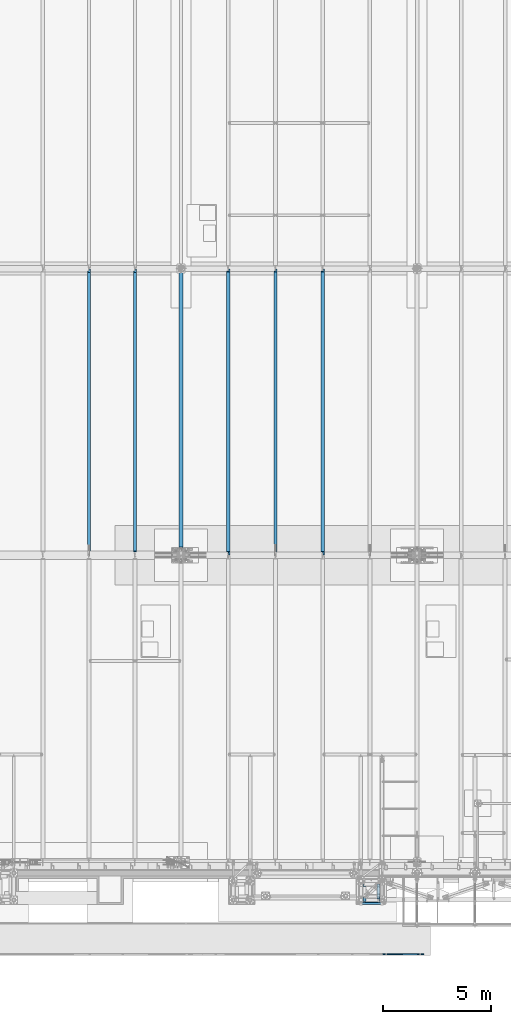
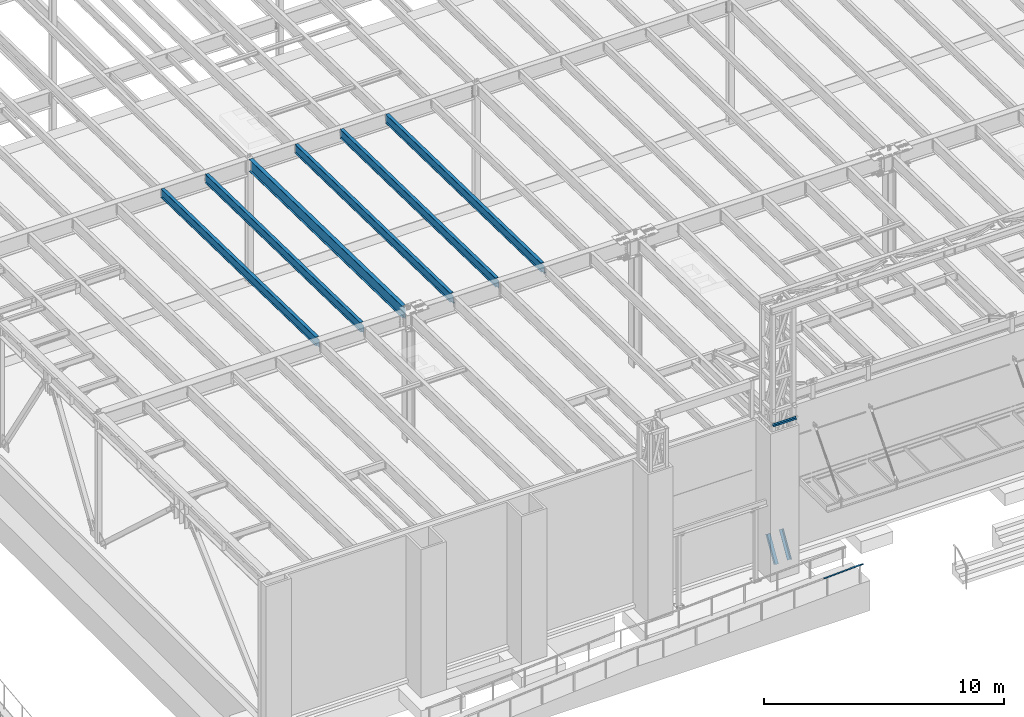
# One storey, part 1051 of 1763: 8 beams, 2 members, 8 elements without a shape of their own.
"""IFC2X3 building model written with IfcOpenShell, lengths in millimetres."""

from ifc_helpers import new_model, si_unit, frame, origin_with_axes, place, context, subcontext, project, spatial, faceted_brep, material, type_object, element, aggregate, save


model = new_model("IFC2X3")

# Units and contexts
model_context = context("Model", 3, precision=1e-05, world=origin_with_axes())
body_context = subcontext(model_context, "Body", "Model", "MODEL_VIEW")
ifc_project = project(units=[si_unit("LENGTHUNIT", "METRE", prefix="MILLI"), si_unit("AREAUNIT", "SQUARE_METRE"), si_unit("VOLUMEUNIT", "CUBIC_METRE"), si_unit("MASSUNIT", "GRAM", prefix="KILO"), si_unit("TIMEUNIT", "SECOND"), si_unit("PLANEANGLEUNIT", "RADIAN"), si_unit("SOLIDANGLEUNIT", "STERADIAN"), si_unit("THERMODYNAMICTEMPERATUREUNIT", "DEGREE_CELSIUS"), si_unit("LUMINOUSINTENSITYUNIT", "LUMEN")], contexts=[model_context])

# Site, building, storey
site_placement = place(None, origin_with_axes())
site = spatial("IfcSite", under=ifc_project, at=site_placement, CompositionType="ELEMENT")
building_placement = place(site_placement, origin_with_axes())
building = spatial("IfcBuilding", under=site, at=building_placement, Name="Undefined", CompositionType="ELEMENT")
storey_placement = place(building_placement, origin_with_axes())
storey = spatial("IfcBuildingStorey", under=building, at=storey_placement, Name="Undefined", CompositionType="ELEMENT", Elevation=0.0)

# Assembly, members, beam
assembly_1_placement = place(storey_placement, origin_with_axes())
assembly_1 = element("IfcElementAssembly", 1, at=assembly_1_placement, inside=storey, Name="FRAME", AssemblyPlace="NOTDEFINED", PredefinedType="RIGID_FRAME")
ifc_material_1 = material(Name="STEEL/A36")
member_type = type_object("IfcMemberType", Name="L6X6X7/8", PredefinedType="NOTDEFINED")
member_1_placement = place(assembly_1_placement, frame((-63375.6025956311, -15452.7273134574, 5676.9), z_axis=(-1.0, 0.0, 0.0), x_axis=(0.0, 0.513027731048337, 0.858372033080875)))
member_1 = element("IfcMember", 2, at=member_1_placement, type_object=member_type, material=ifc_material_1, Name="V. BRACE", ObjectType="L6X6X7/8", context=body_context, shape_type="Brep", body=[
    faceted_brep([(9.09494701772928e-13, 76.2000000000007, -76.2000000000844), (0.0, 76.2000000000007, 76.2000000000771), (1326.04215441225, 76.2000000009157, 76.1999999999971), (1326.04215441225, 76.2000000009157, -76.1999999999971), (0.0, 53.9750000000004, 76.2000000000771), (1326.04215441225, 53.9750000009208, 76.1999999999971), (1.81898940354586e-12, 53.9750000000004, -53.9750000000604), (1326.04215441225, 53.9750000009208, -53.9749999999985), (1.81898940354586e-12, -76.2000000000007, -53.9750000000604), (1326.04215441224, -76.199999999053, -53.9749999999985), (9.09494701772928e-13, -76.2000000000007, -76.2000000000844), (1326.04215441224, -76.199999999053, -76.1999999999971)], [[[0, 1, 2, 3]], [[1, 4, 5, 2]], [[4, 6, 7, 5]], [[6, 8, 9, 7]], [[8, 10, 11, 9]], [[10, 0, 3, 11]], [[5, 7, 9, 11, 3, 2]], [[10, 8, 6, 4, 1, 0]]]),
])
member_2_placement = place(assembly_1_placement, frame((-64020.1273899732, -15452.7273151589, 5676.9), z_axis=(1.0, 0.0, 0.0), x_axis=(0.0, 0.513027731048337, 0.858372033080875)))
member_2 = element("IfcMember", 3, at=member_2_placement, type_object=member_type, material=ifc_material_1, Name="V. BRACE", ObjectType="L6X6X7/8", context=body_context, shape_type="Brep", body=[
    faceted_brep([(9.09494701772928e-13, 76.2000000000007, -76.2000000000844), (0.0, 76.2000000000007, 76.2000000000771), (1326.04215441225, 76.2000000009157, 76.1999999999971), (1326.04215441225, 76.2000000009157, -76.1999999999971), (0.0, 53.9750000000004, 76.2000000000771), (1326.04215441225, 53.9750000009208, 76.1999999999971), (1.81898940354586e-12, 53.9750000000004, -53.9750000000604), (1326.04215441225, 53.9750000009208, -53.9749999999985), (1.81898940354586e-12, -76.2000000000007, -53.9750000000604), (1326.04215441224, -76.199999999053, -53.9749999999985), (9.09494701772928e-13, -76.2000000000007, -76.2000000000844), (1326.04215441224, -76.199999999053, -76.1999999999971)], [[[0, 1, 2, 3]], [[1, 4, 5, 2]], [[4, 6, 7, 5]], [[6, 8, 9, 7]], [[8, 10, 11, 9]], [[10, 0, 3, 11]], [[5, 7, 9, 11, 3, 2]], [[10, 8, 6, 4, 1, 0]]]),
])
beam_type_1 = type_object("IfcBeamType", Name="L4X4X3/8", PredefinedType="NOTDEFINED")
beam_1_placement = place(assembly_1_placement, frame((-63134.3025957006, -15608.3024208798, 12903.2), z_axis=(0.0, -1.0, 0.0), x_axis=(-1.0, 0.0, 0.0)))
beam_1 = element("IfcBeam", 4, at=beam_1_placement, type_object=beam_type_1, material=ifc_material_1, Name="ANGLE", ObjectType="L4X4X3/8", context=body_context, shape_type="Brep", body=[
    faceted_brep([(-3.63797880709171e-11, 50.8000000000011, -50.8000000000538), (-1.96450855582952e-10, 50.8000000000393, 50.7999999999374), (1127.1251953125, 50.7999999999993, 50.7999999999993), (1127.1251953125, 50.7999999999993, -50.7999999999993), (0.0, 41.2749999999996, 50.7999999999993), (1127.1251953125, 41.2749999999996, 50.7999999999993), (0.0, 41.2749999999996, -41.2750000000015), (1127.1251953125, 41.2749999999996, -41.2749999999996), (0.0, -50.7999999999993, -41.2750000000015), (1127.1251953125, -50.7999999999993, -41.2749999999996), (2.11002770811319e-10, -50.8000000000357, -50.799999999952), (1127.1251953125, -50.7999999999993, -50.7999999999993)], [[[0, 1, 2, 3]], [[1, 4, 5, 2]], [[4, 6, 7, 5]], [[6, 8, 9, 7]], [[8, 10, 11, 9]], [[10, 0, 3, 11]], [[5, 7, 9, 11, 3, 2]], [[10, 8, 6, 4, 1, 0]]]),
])
aggregate(assembly_1, [beam_1, member_1, member_2])

# Assembly, beam
assembly_2_placement = place(storey_placement, origin_with_axes())
assembly_2 = element("IfcElementAssembly", 5, at=assembly_2_placement, inside=storey, Name="HANDRAIL", AssemblyPlace="NOTDEFINED", PredefinedType="RIGID_FRAME")
beam_type_2 = type_object("IfcBeamType", PredefinedType="NOTDEFINED")
beam_2_placement = place(assembly_2_placement, frame((-63170.3544175437, -17957.80011631, 6173.15296081485), z_axis=(0.0, 1.0, 0.0), x_axis=(0.998862153652615, 0.0, 0.0476906489834141)))
beam_2 = element("IfcBeam", 6, at=beam_2_placement, type_object=beam_type_2, material=ifc_material_1, Name="HANDRAIL", context=body_context, shape_type="Brep", body=[
    faceted_brep([(2.91038304567337e-11, -9.52499999999418, -25.4000000000015), (2.91038304567337e-11, -9.52499999999418, 25.4000000000015), (-5.82076609134674e-11, 9.52499999999418, 25.4000000000015), (-5.82076609134674e-11, 9.52499999999418, -25.4000000000015), (1577.64893967877, 9.5250031540254, 25.4000000000015), (1577.64893967877, 9.5250031540254, -25.4000000000015), (1578.10337826535, -9.52499684506802, -25.4000000000015), (1578.10337826535, -9.52499684506802, 25.4000000000015), (1881.72603368139, 24.0408078176079, 25.4000000000015), (1881.72603368139, 24.0408078176079, -25.4000000000015), (1882.63439390225, 5.01247678966138, 25.4000000000015), (1882.63439390225, 5.01247678966138, -25.4000000000015)], [[[0, 1, 2, 3]], [[3, 2, 4, 5]], [[1, 0, 6, 7]], [[5, 4, 8, 9]], [[4, 2, 1, 7, 10, 8]], [[7, 6, 11, 10]], [[6, 0, 3, 5, 9, 11]], [[10, 11, 9, 8]]]),
])
aggregate(assembly_2, [beam_2])

assembly_3_placement = place(storey_placement, origin_with_axes())
assembly_3 = element("IfcElementAssembly", 7, at=assembly_3_placement, inside=storey, Name="BEAM", AssemblyPlace="NOTDEFINED", PredefinedType="RIGID_FRAME")
ifc_material_2 = material(Name="STEEL/A992")
beam_type_3 = type_object("IfcBeamType", Name="W18X40", PredefinedType="NOTDEFINED")
beam_3_placement = place(assembly_3_placement, frame((-65953.0772736983, 452.455130930327, 11681.4332640109), z_axis=(0.0, 0.0209013539966291, 0.999781542838788), x_axis=(0.0, 0.999781542776098, -0.0209013569953182)))
beam_3 = element("IfcBeam", 8, at=beam_3_placement, type_object=beam_type_3, material=ifc_material_2, Name="BEAM", ObjectType="W18X40", context=body_context, shape_type="Brep", body=[
    faceted_brep([(13125.1458004226, 4.26884714065818, -214.312500004715), (13125.1458004227, 4.268649864287, -227.012500004723), (13125.1457929416, 76.1999999999971, -227.012500004725), (13125.1457929416, 76.1999999999971, -214.312500004715), (13226.7292124126, 4.26866042923211, -227.012500004759), (13226.4637071899, 4.26885767801286, -214.312500004749), (170.643991777441, 3.96875, 214.312500000113), (170.643991777441, 76.1999999999971, 214.312500000113), (13088.6333065581, 76.1999999999971, 214.31249999564), (13088.6333065581, 3.96875, 214.31249999564), (170.64399177744, -76.1999999999971, 227.012500000121), (170.64399177744, 76.1999999999971, 227.012500000121), (170.643991777481, 3.96875, 182.302497673005), (170.643991777481, -3.96875, 182.302497673005), (170.643991777441, -3.96875, 214.312500000113), (170.643991777441, -76.1999999999971, 214.312500000113), (169.677261854896, 3.96875, 177.442418154946), (169.677261854896, -3.96875, 177.442418154946), (166.92424795442, 3.96875, 173.322241686783), (166.92424795442, -3.96875, 173.322241686783), (162.804071486266, 3.96875, 170.569227786298), (162.804071486266, -3.96875, 170.569227786298), (157.94399196822, 3.96875, 169.602497863712), (157.94399196822, -3.96875, 169.602497863712), (21.0482950088172, 3.96875, 169.602497863712), (21.0482950088172, -3.96875, 169.602497863712), (29.0743924101943, -3.96875, -214.31250000018), (29.0743924101943, -76.1999999999971, -214.31250000018), (13226.4637071899, -76.1999999999971, -214.312500004749), (13226.4637071899, -3.96875, -214.312500004749), (13096.4732268494, -3.96875, 183.269231527978), (13092.3530503812, -3.96875, 186.022245428465), (13089.6000364807, -3.96875, 190.142421896631), (13088.6333065582, -3.96875, 195.002501414689), (13088.6333065581, -3.96875, 214.31249999564), (13218.1721044876, -3.96875, 182.302501605345), (13101.3333063674, -3.96875, 182.302501605383), (13088.6333065581, -76.1999999999971, 214.31249999564), (13088.6333065581, -76.1999999999971, 227.01249999565), (13088.6333065581, 76.1999999999971, 227.01249999565), (13088.6333065582, 3.96875, 195.002501414689), (13089.6000364807, 3.96875, 190.142421896631), (13092.3530503812, 3.96875, 186.022245428465), (13096.4732268494, 3.96875, 183.269231527978), (13101.3333063674, 3.96875, 182.302501605383), (13218.1721044876, 3.96875, 182.302501605345), (13226.4637071899, 3.96875, -214.312500004749), (29.0743924101943, 3.96875, -214.31250000018), (170.643992393003, 76.1999999999971, -214.312500000229), (170.643992392998, 76.1999999999971, -227.012500000241), (170.644001240348, 4.26884710787999, -227.012500000241), (170.644001240369, 4.26864982827101, -214.312500000229), (29.339897632873, 4.26882972748717, -227.01250000019), (29.0743924101943, 4.26863241521642, -214.31250000018), (29.339897632873, -76.1999999999971, -227.01250000019), (13226.7292124126, -76.1999999999971, -227.012500004759)], [[[0, 1, 2, 3]], [[4, 1, 0, 5]], [[6, 7, 8, 9]], [[10, 11, 7, 6, 12, 13, 14, 15]], [[13, 12, 16, 17]], [[17, 16, 18, 19]], [[19, 18, 20, 21]], [[21, 20, 22, 23]], [[23, 22, 24, 25]], [[26, 27, 28, 29]], [[30, 31, 32, 33, 34, 14, 13, 17, 19, 21, 23, 25, 26, 29, 35, 36]], [[15, 14, 34, 37]], [[10, 15, 37, 38]], [[11, 10, 38, 39]], [[7, 11, 39, 8]], [[38, 37, 34, 33, 40, 9, 8, 39]], [[32, 41, 40, 33]], [[31, 42, 41, 32]], [[30, 43, 42, 31]], [[36, 44, 43, 30]], [[35, 45, 44, 36]], [[46, 47, 24, 22, 20, 18, 16, 12, 6, 9, 40, 41, 42, 43, 44, 45]], [[48, 49, 50, 51]], [[51, 50, 52, 53]], [[54, 27, 26, 25, 24, 47, 53, 52]], [[27, 54, 55, 28]], [[46, 45, 35, 29, 28, 55, 4, 5]], [[3, 48, 51, 53, 47, 46, 5, 0]], [[49, 48, 3, 2]], [[55, 54, 52, 50, 49, 2, 1, 4]]]),
])
aggregate(assembly_3, [beam_3])

assembly_4_placement = place(storey_placement, origin_with_axes())
assembly_4 = element("IfcElementAssembly", 9, at=assembly_4_placement, inside=storey, Name="BEAM", AssemblyPlace="NOTDEFINED", PredefinedType="RIGID_FRAME")
beam_4_placement = place(assembly_4_placement, frame((-68132.3972736983, 452.455130930327, 11681.4332640109), z_axis=(0.0, 0.0209013539966291, 0.999781542838788), x_axis=(0.0, 0.999781542776098, -0.0209013569953182)))
beam_4 = element("IfcBeam", 10, at=beam_4_placement, type_object=beam_type_3, material=ifc_material_2, Name="BEAM", ObjectType="W18X40", context=body_context, shape_type="Brep", body=[
    faceted_brep([(29.0743924101943, -3.96875, -214.31250000018), (29.3398976328791, -3.96867297649442, -227.01250000019), (172.24808792756, -3.9686593998631, -227.012500000241), (172.248087927576, -3.96875, -214.312500000231), (172.2480947897, -76.1999999999971, -214.312500000231), (172.248094789697, -76.1999999999971, -227.012500000241), (13125.1458004226, 4.26884714065818, -214.312500004715), (13125.1458004227, 4.268649864287, -227.012500004723), (13125.1457929416, 76.1999999999971, -227.012500004725), (13125.1457929416, 76.1999999999971, -214.312500004715), (172.248086396876, 76.1999999999971, -227.012500000241), (172.24808639688, 76.1999999999971, -214.312500000231), (172.248093258896, 3.96884671709995, -227.012500000241), (172.248093258908, 3.96865936378163, -214.312500001566), (80.1509976836787, 3.96924991607375, -227.01250000021), (79.8854924610018, 3.96875, -214.3125000002), (29.3398976328791, 3.96924991607375, -227.01250000019), (29.0743924101943, 3.96875, -214.31250000018), (172.248085922071, 3.96875, 214.312500000111), (172.248085922071, 76.1999999999971, 214.312500000111), (13088.6333065581, 76.1999999999971, 214.31249999564), (13088.6333065581, 3.96875, 214.31249999564), (13226.4637071899, 3.96875, -214.312500004749), (28.8925342149054, 3.96875, -205.61361491684), (21.0428594241718, 3.96875, 169.862499999928), (159.54808611285, 3.96875, 169.86249999993), (164.408165630896, 3.96875, 170.829229922516), (168.52834209905, 3.96875, 173.582243823001), (171.281355999526, 3.96875, 177.702420291163), (172.248085922111, 3.96875, 182.562499809223), (13088.6333065582, 3.96875, 195.002501414689), (13089.6000364807, 3.96875, 190.142421896631), (13092.3530503812, 3.96875, 186.022245428465), (13096.4732268494, 3.96875, 183.269231527978), (13101.3333063674, 3.96875, 182.302501605383), (13218.1721044876, 3.96875, 182.302501605345), (13226.4637071899, 4.26885767801286, -214.312500004749), (13226.7292124126, 4.26866042923211, -227.012500004759), (13218.1721044876, -3.96875, 182.302501605345), (13226.4637071899, -3.96875, -214.312500004749), (13226.4637071899, -76.1999999999971, -214.312500004749), (13226.7292124126, -76.1999999999971, -227.012500004759), (28.8925416367893, -3.96875, -205.613969930291), (21.0428594241718, -3.96875, 169.862499999928), (159.54808611285, -3.96875, 169.86249999993), (164.408165630896, -3.96875, 170.829229922516), (168.52834209905, -3.96875, 173.582243823001), (171.281355999526, -3.96875, 177.702420291163), (172.248085922111, -3.96875, 182.562499809223), (172.24808592207, -76.1999999999971, 227.012500000121), (172.24808592207, 76.1999999999971, 227.012500000121), (172.248085922071, -3.96875, 214.312500000111), (172.248085922071, -76.1999999999971, 214.312500000111), (13088.6333065581, -3.96875, 214.31249999564), (13088.6333065581, -76.1999999999971, 214.31249999564), (13088.6333065581, -76.1999999999971, 227.01249999565), (13088.6333065581, 76.1999999999971, 227.01249999565), (13088.6333065582, -3.96875, 195.002501414689), (13089.6000364807, -3.96875, 190.142421896631), (13092.3530503812, -3.96875, 186.022245428465), (13096.4732268494, -3.96875, 183.269231527978), (13101.3333063674, -3.96875, 182.302501605383)], [[[0, 1, 2, 3]], [[4, 3, 2, 5]], [[6, 7, 8, 9]], [[10, 11, 9, 8]], [[11, 10, 12, 13]], [[13, 12, 14, 15]], [[16, 17, 15, 14]], [[18, 19, 20, 21]], [[22, 13, 15, 17, 23, 24, 25, 26, 27, 28, 29, 18, 21, 30, 31, 32, 33, 34, 35]], [[9, 11, 13, 22, 36, 6]], [[37, 7, 6, 36]], [[22, 35, 38, 39, 40, 41, 37, 36]], [[41, 40, 4, 5]], [[1, 16, 14, 12, 10, 8, 7, 37, 41, 5, 2]], [[42, 43, 24, 23, 17, 16, 1, 0]], [[44, 25, 24, 43]], [[45, 26, 25, 44]], [[46, 27, 26, 45]], [[47, 28, 27, 46]], [[48, 29, 28, 47]], [[49, 50, 19, 18, 29, 48, 51, 52]], [[52, 51, 53, 54]], [[49, 52, 54, 55]], [[50, 49, 55, 56]], [[19, 50, 56, 20]], [[55, 54, 53, 57, 30, 21, 20, 56]], [[58, 31, 30, 57]], [[59, 32, 31, 58]], [[60, 33, 32, 59]], [[61, 34, 33, 60]], [[38, 35, 34, 61]], [[60, 59, 58, 57, 53, 51, 48, 47, 46, 45, 44, 43, 42, 0, 3, 39, 38, 61]], [[40, 39, 3, 4]]]),
])
aggregate(assembly_4, [beam_4])

assembly_5_placement = place(storey_placement, origin_with_axes())
assembly_5 = element("IfcElementAssembly", 11, at=assembly_5_placement, inside=storey, Name="BEAM", AssemblyPlace="NOTDEFINED", PredefinedType="RIGID_FRAME")
beam_5_placement = place(assembly_5_placement, frame((-70311.7172736983, 452.455130930327, 11681.4332640109), z_axis=(0.0, 0.0209013539966291, 0.999781542838788), x_axis=(0.0, 0.999781542776098, -0.0209013569953182)))
beam_5 = element("IfcBeam", 12, at=beam_5_placement, type_object=beam_type_3, material=ifc_material_2, Name="BEAM", ObjectType="W18X40", context=body_context, shape_type="Brep", body=[
    faceted_brep([(13125.1458004226, 4.26884714065818, -214.312500004715), (13125.1458004227, 4.268649864287, -227.012500004723), (13125.1457929416, 76.1999999999971, -227.012500004725), (13125.1457929416, 76.1999999999971, -214.312500004715), (13226.7292124126, 4.26866042923211, -227.012500004759), (13226.4637071899, 4.26885767801286, -214.312500004749), (170.643991777441, 3.96875, 214.312500000113), (170.643991777441, 76.1999999999971, 214.312500000113), (13088.6333065581, 76.1999999999971, 214.31249999564), (13088.6333065581, 3.96875, 214.31249999564), (170.64399177744, -76.1999999999971, 227.012500000121), (170.64399177744, 76.1999999999971, 227.012500000121), (170.643991777481, 3.96875, 182.302497673005), (170.643991777481, -3.96875, 182.302497673005), (170.643991777441, -3.96875, 214.312500000113), (170.643991777441, -76.1999999999971, 214.312500000113), (169.677261854896, 3.96875, 177.442418154946), (169.677261854896, -3.96875, 177.442418154946), (166.92424795442, 3.96875, 173.322241686783), (166.92424795442, -3.96875, 173.322241686783), (162.804071486266, 3.96875, 170.569227786298), (162.804071486266, -3.96875, 170.569227786298), (157.94399196822, 3.96875, 169.602497863712), (157.94399196822, -3.96875, 169.602497863712), (21.0482950088172, 3.96875, 169.602497863712), (21.0482950088172, -3.96875, 169.602497863712), (29.0743924101943, -3.96875, -214.31250000018), (29.0743924101943, -76.1999999999971, -214.31250000018), (13226.4637071899, -76.1999999999971, -214.312500004749), (13226.4637071899, -3.96875, -214.312500004749), (13096.4732268494, -3.96875, 183.269231527978), (13092.3530503812, -3.96875, 186.022245428465), (13089.6000364807, -3.96875, 190.142421896631), (13088.6333065582, -3.96875, 195.002501414689), (13088.6333065581, -3.96875, 214.31249999564), (13218.1721044876, -3.96875, 182.302501605345), (13101.3333063674, -3.96875, 182.302501605383), (13088.6333065581, -76.1999999999971, 214.31249999564), (13088.6333065581, -76.1999999999971, 227.01249999565), (13088.6333065581, 76.1999999999971, 227.01249999565), (13088.6333065582, 3.96875, 195.002501414689), (13089.6000364807, 3.96875, 190.142421896631), (13092.3530503812, 3.96875, 186.022245428465), (13096.4732268494, 3.96875, 183.269231527978), (13101.3333063674, 3.96875, 182.302501605383), (13218.1721044876, 3.96875, 182.302501605345), (13226.4637071899, 3.96875, -214.312500004749), (29.0743924101943, 3.96875, -214.31250000018), (170.643992393003, 76.1999999999971, -214.312500000229), (170.643992392998, 76.1999999999971, -227.012500000241), (170.644001240348, 4.26884710787999, -227.012500000241), (170.644001240369, 4.26864982827101, -214.312500000229), (29.339897632873, 4.26882972748717, -227.01250000019), (29.0743924101943, 4.26863241521642, -214.31250000018), (29.339897632873, -76.1999999999971, -227.01250000019), (13226.7292124126, -76.1999999999971, -227.012500004759)], [[[0, 1, 2, 3]], [[4, 1, 0, 5]], [[6, 7, 8, 9]], [[10, 11, 7, 6, 12, 13, 14, 15]], [[13, 12, 16, 17]], [[17, 16, 18, 19]], [[19, 18, 20, 21]], [[21, 20, 22, 23]], [[23, 22, 24, 25]], [[26, 27, 28, 29]], [[30, 31, 32, 33, 34, 14, 13, 17, 19, 21, 23, 25, 26, 29, 35, 36]], [[15, 14, 34, 37]], [[10, 15, 37, 38]], [[11, 10, 38, 39]], [[7, 11, 39, 8]], [[38, 37, 34, 33, 40, 9, 8, 39]], [[32, 41, 40, 33]], [[31, 42, 41, 32]], [[30, 43, 42, 31]], [[36, 44, 43, 30]], [[35, 45, 44, 36]], [[46, 47, 24, 22, 20, 18, 16, 12, 6, 9, 40, 41, 42, 43, 44, 45]], [[48, 49, 50, 51]], [[51, 50, 52, 53]], [[54, 27, 26, 25, 24, 47, 53, 52]], [[27, 54, 55, 28]], [[46, 45, 35, 29, 28, 55, 4, 5]], [[3, 48, 51, 53, 47, 46, 5, 0]], [[49, 48, 3, 2]], [[55, 54, 52, 50, 49, 2, 1, 4]]]),
])
aggregate(assembly_5, [beam_5])

assembly_6_placement = place(storey_placement, origin_with_axes())
assembly_6 = element("IfcElementAssembly", 13, at=assembly_6_placement, inside=storey, Name="BEAM", AssemblyPlace="NOTDEFINED", PredefinedType="RIGID_FRAME")
beam_6_placement = place(assembly_6_placement, frame((-74617.3801308412, 452.455130930327, 11681.4332640109), z_axis=(0.0, 0.0209013539966291, 0.999781542838788), x_axis=(0.0, 0.999781542776098, -0.0209013569953182)))
beam_6 = element("IfcBeam", 14, at=beam_6_placement, type_object=beam_type_3, material=ifc_material_2, Name="BEAM", ObjectType="W18X40", context=body_context, shape_type="Brep", body=[
    faceted_brep([(29.868315875358, -4.26886479998939, -214.31250000018), (30.1338210980368, -4.26866747500026, -227.012500000192), (152.387927582892, -4.268649869613, -227.012500000232), (152.387927582916, -4.26884715634515, -214.312500000224), (152.387937941428, -76.1999999999971, -214.312500000224), (152.387937941423, -76.1999999999971, -227.012500000232), (203.187915242645, -3.96875, 175.95249767303), (203.187915242645, 3.96875, 175.95249767303), (202.221185320061, 3.96875, 171.092418154973), (202.221185320061, -3.96875, 171.092418154973), (199.468171419584, 3.96875, 166.972241686808), (199.468171419584, -3.96875, 166.972241686808), (195.347994951431, 3.96875, 164.219227786325), (195.347994951431, -3.96875, 164.219227786325), (190.487915433385, 3.96875, 163.252497863739), (190.487915433385, -3.96875, 163.252497863739), (21.9749710853197, 3.96875, 163.252497863738), (21.9749710853197, -3.96875, 163.252497863738), (29.868315875358, -3.96875, -214.31250000018), (13225.6697837248, -3.96875, -214.312500004749), (13217.3781810224, -3.96875, 182.302501605274), (13081.4893829022, -3.96875, 182.30250160532), (13076.6293033842, -3.96875, 183.269231527915), (13072.509126916, -3.96875, 186.022245428401), (13069.7561130155, -3.96875, 190.142421896568), (13068.7893830929, -3.96875, 195.002501414625), (13068.7893830929, -3.96875, 214.312499995647), (203.187915242602, -3.96875, 214.312500000102), (13217.3781810224, 3.96875, 182.302501605274), (13081.4893829022, 3.96875833510421, 182.30250160532), (13076.6293033842, 3.96875843712041, 183.269231527915), (13072.509126916, 3.96875872778764, 186.022245428401), (13069.7561130155, 3.96875916284625, 190.142421896568), (13068.7893830929, 3.96875967607048, 195.002501414625), (13068.7893830929, -76.1999999999971, 227.012499995655), (13068.7893830929, -76.1999999999971, 214.312499995647), (13068.7893830929, 3.96875, 214.312499995647), (13068.7893830929, 76.1999999999971, 214.312499995647), (13068.7893830929, 76.1999999999971, 227.012499995655), (203.187915242602, 3.96875, 214.312500000102), (203.187915242602, 76.1999999999971, 214.312500000102), (203.187915242601, 76.1999999999971, 227.012500000112), (203.187915242601, -76.1999999999971, 227.012500000112), (203.187915242602, -76.1999999999971, 214.312500000102), (13225.6697837248, 3.96875, -214.312500004749), (29.868315875358, 3.96875, -214.31250000018), (13125.9393797543, 4.26884708629223, -214.312500004713), (13125.9393797543, 4.2686498080584, -227.012500004725), (13125.9393716976, 76.1999999999971, -227.012500004725), (13125.9393716976, 76.1999999999971, -214.312500004717), (152.387915963997, 76.1999999999971, -227.012500000234), (152.387915964001, 76.1999999999971, -214.312500000224), (152.387926321661, 4.26884710819286, -227.012500000232), (152.387926321684, 4.26864982147526, -214.312500000222), (30.1338210980368, 4.26882950359141, -227.012500000192), (29.868315875358, 4.26863217861683, -214.31250000018), (13225.6697837248, 4.26885846266669, -214.312500004749), (13225.9352889475, 4.26866120118211, -227.012500004759), (13225.6697837248, -76.1999999999971, -214.312500004749), (13225.9352889475, -76.1999999999971, -227.012500004759)], [[[0, 1, 2, 3]], [[4, 3, 2, 5]], [[6, 7, 8, 9]], [[9, 8, 10, 11]], [[11, 10, 12, 13]], [[13, 12, 14, 15]], [[15, 14, 16, 17]], [[9, 11, 13, 15, 17, 18, 19, 20, 21, 22, 23, 24, 25, 26, 27, 6]], [[20, 28, 29, 21]], [[21, 29, 30, 22]], [[22, 30, 31, 23]], [[23, 31, 32, 24]], [[24, 32, 33, 25]], [[34, 35, 26, 25, 33, 36, 37, 38]], [[37, 36, 39, 40]], [[38, 37, 40, 41]], [[34, 38, 41, 42]], [[35, 34, 42, 43]], [[26, 35, 43, 27]], [[42, 41, 40, 39, 7, 6, 27, 43]], [[36, 33, 32, 31, 30, 29, 28, 44, 45, 16, 14, 12, 10, 8, 7, 39]], [[46, 47, 48, 49]], [[49, 48, 50, 51]], [[51, 50, 52, 53]], [[53, 52, 54, 55]], [[45, 44, 56, 46, 49, 51, 53, 55]], [[57, 47, 46, 56]], [[44, 28, 20, 19, 58, 59, 57, 56]], [[59, 58, 4, 5]], [[1, 54, 52, 50, 48, 47, 57, 59, 5, 2]], [[18, 17, 16, 45, 55, 54, 1, 0]], [[58, 19, 18, 0, 3, 4]]]),
])
aggregate(assembly_6, [beam_6])

assembly_7_placement = place(storey_placement, origin_with_axes())
assembly_7 = element("IfcElementAssembly", 15, at=assembly_7_placement, inside=storey, Name="BEAM", AssemblyPlace="NOTDEFINED", PredefinedType="RIGID_FRAME")
beam_7_placement = place(assembly_7_placement, frame((-76743.7229879841, 452.455130930327, 11681.4332640109), z_axis=(0.0, 0.0209013539966291, 0.999781542838788), x_axis=(0.0, 0.999781542776098, -0.0209013569953182)))
beam_7 = element("IfcBeam", 16, at=beam_7_placement, type_object=beam_type_3, material=ifc_material_2, Name="BEAM", ObjectType="W18X40", context=body_context, shape_type="Brep", body=[
    faceted_brep([(219.0880995212, -3.96799993515015, -227.012500000257), (218.822594298523, -3.96875, -214.312500000246), (29.868315875358, -3.96875, -214.31250000018), (30.1338210980368, -3.96799993515015, -227.012500000192), (219.088099521062, -76.1999999999971, -227.012500000257), (218.822594298385, -76.1999999999971, -214.312500000246), (13068.7893830929, -76.1999999999971, 227.012499995655), (13068.7893830929, -76.1999999999971, 214.312499995647), (13068.7893830929, -3.96875, 214.312499995647), (13068.7893830929, -3.96875, 195.002501414625), (13068.7893830929, 3.96875967607048, 195.002501414625), (13068.7893830929, 3.96875, 214.312499995647), (13068.7893830929, 76.1999999999971, 214.312499995647), (13068.7893830929, 76.1999999999971, 227.012499995655), (13069.7561130155, -3.96875, 190.142421896568), (13069.7561130155, 3.96875916284625, 190.142421896568), (13072.509126916, -3.96875, 186.022245428401), (13072.509126916, 3.96875872778764, 186.022245428401), (13076.6293033842, -3.96875, 183.269231527915), (13076.6293033842, 3.96875843712041, 183.269231527915), (13081.4893829022, -3.96875, 182.30250160532), (13081.4893829022, 3.96875833510421, 182.30250160532), (13217.3781810224, -3.96875, 182.302501605274), (13217.3781810224, 3.96875, 182.302501605274), (30.1338210980368, 3.9695000648353, -227.012500000192), (29.868315875358, 3.96875, -214.31250000018), (218.822594298523, 3.96875, -214.312500000246), (219.0880995212, 3.9695000648353, -227.012500000257), (13125.9393797543, 4.26884708629223, -214.312500004713), (13125.9393797543, 4.2686498080584, -227.012500004725), (13125.9393716976, 76.1999999999971, -227.012500004725), (13125.9393716976, 76.1999999999971, -214.312500004717), (219.08809952106, 76.1999999999971, -227.012500000257), (218.822594298387, 76.1999999999971, -214.312500000246), (13225.6697837248, 3.96875, -214.312500004749), (13225.6697837248, 4.26885846266669, -214.312500004749), (13225.9352889475, 4.26866120118211, -227.012500004759), (13225.6697837248, -3.96875, -214.312500004749), (13225.6697837248, -76.1999999999971, -214.312500004749), (13225.9352889475, -76.1999999999971, -227.012500004759), (21.8699710421643, -3.96875, 168.274999999931), (21.8699710421643, 3.96875, 168.274999999931), (204.792009578009, -3.96875, 168.274999999932), (204.792009578009, 3.96875, 168.274999999932), (209.652089096055, -3.96875, 169.24172992252), (209.652089096055, 3.96875, 169.24172992252), (210.788169303168, -3.96875, 170.000834447877), (213.772265564209, -3.96875, 171.994743823003), (213.772265564209, 3.96875, 171.994743823003), (216.525279464685, -3.96875, 176.114920291167), (216.525279464685, 3.96875, 176.114920291167), (217.49200938727, -3.96875, 180.974999809225), (217.49200938727, 3.96875, 180.974999809225), (217.49200938723, 3.96875, 214.312500000095), (217.49200938723, 76.1999999999971, 214.312500000095), (217.49200938723, 76.1999999999971, 227.012500000106), (217.49200938723, -76.1999999999971, 227.012500000106), (217.49200938723, -76.1999999999971, 214.312500000095), (217.49200938723, -3.96875, 214.312500000095)], [[[0, 1, 2, 3]], [[4, 5, 1, 0]], [[6, 7, 8, 9, 10, 11, 12, 13]], [[14, 15, 10, 9]], [[16, 17, 15, 14]], [[18, 19, 17, 16]], [[20, 21, 19, 18]], [[22, 23, 21, 20]], [[24, 25, 26, 27]], [[28, 29, 30, 31]], [[31, 30, 32, 33]], [[27, 26, 33, 32]], [[34, 35, 28, 31, 33, 26]], [[36, 29, 28, 35]], [[34, 23, 22, 37, 38, 39, 36, 35]], [[3, 24, 27, 32, 30, 29, 36, 39, 4, 0]], [[40, 41, 25, 24, 3, 2]], [[42, 43, 41, 40]], [[44, 45, 43, 42]], [[46, 47, 48, 45, 44]], [[49, 50, 48, 47]], [[51, 52, 50, 49]], [[11, 10, 15, 17, 19, 21, 23, 34, 26, 25, 41, 43, 45, 48, 50, 52, 53]], [[12, 11, 53, 54]], [[13, 12, 54, 55]], [[6, 13, 55, 56]], [[7, 6, 56, 57]], [[8, 7, 57, 58]], [[56, 55, 54, 53, 52, 51, 58, 57]], [[49, 47, 46, 44, 42, 40, 2, 1, 37, 22, 20, 18, 16, 14, 9, 8, 58, 51]], [[38, 37, 1, 5]], [[39, 38, 5, 4]]]),
])
aggregate(assembly_7, [beam_7])

assembly_8_placement = place(storey_placement, origin_with_axes())
assembly_8 = element("IfcElementAssembly", 17, at=assembly_8_placement, inside=storey, Name="BEAM", AssemblyPlace="NOTDEFINED", PredefinedType="RIGID_FRAME")
beam_type_4 = type_object("IfcBeamType", Name="W24X55", PredefinedType="NOTDEFINED")
beam_8_placement = place(assembly_8_placement, frame((-72491.0372736984, 450.92880941152, 11608.424216848), z_axis=(0.0, 0.0209013539966291, 0.999781542838788), x_axis=(0.0, 0.999781542776098, -0.0209013569953182)))
beam_8 = element("IfcBeam", 18, at=beam_8_placement, type_object=beam_type_4, material=ifc_material_2, Name="BEAM", ObjectType="W24X55", context=body_context, shape_type="Brep", body=[
    faceted_brep([(244.105256572783, -5.06278352974186, -287.337500000313), (244.370761706523, -5.06254405699292, -300.037500000324), (377.798369822044, -5.06237887409225, -300.03750000037), (377.798369822335, -5.06261801818619, -287.33750000036), (377.798473612768, -88.9000000000015, -287.33750000036), (377.798473612763, -88.9000000000015, -300.037500000371), (377.798202921933, -4.76249999999709, 261.677501487717), (377.798202921933, 4.76249999999709, 261.677501487717), (376.831472999348, 4.76249999999709, 256.817421969659), (376.831472999348, -4.76249999999709, 256.817421969659), (374.078459098872, 4.76249999999709, 252.697245501497), (374.078459098872, -4.76249999999709, 252.697245501497), (369.958282630718, 4.76249999999709, 249.944231601014), (369.958282630718, -4.76249999999709, 249.944231601014), (365.098203112672, 4.76249999999709, 248.977501678426), (365.098203112672, -4.76249999999709, 248.977501678426), (232.893100175356, 4.76249999999709, 248.977501678424), (232.893100175356, -4.76249999999709, 248.977501678424), (244.105256572783, -4.76249999999709, -287.337500000313), (13108.8406546312, -4.76249999999709, -287.337500004767), (13096.826543305, -4.76249999999709, 287.337499995696), (377.798202921895, -4.76249999999709, 287.337500000098), (13096.826543305, 88.9000000000015, 287.337499995696), (13096.826543305, 4.76249999999709, 287.337499995696), (377.798202921895, 4.76249999999709, 287.337500000098), (377.798202921895, 88.9000000000015, 287.337500000098), (13096.5610380823, 88.9000000000015, 300.037499995706), (377.798202921896, 88.9000000000015, 300.037500000108), (13096.5610380823, -88.9000000000015, 300.037499995706), (377.798202921896, -88.9000000000015, 300.037500000108), (13096.826543305, -88.9000000000015, 287.337499995696), (377.798202921895, -88.9000000000015, 287.337500000098), (13108.8406546312, 4.76249999999709, -287.337500004767), (244.105256572783, 4.76249999999709, -287.337500000313), (13108.8406546312, 88.9000000000015, -287.337500004767), (377.798209111402, 88.9000000000015, -287.337500000362), (377.7983129025, 5.06237887877069, -287.33750000036), (244.105256572783, 5.06221336682938, -287.337500000313), (377.798312902209, 5.06261802286463, -300.03750000037), (244.370761706523, 5.06245283957833, -300.037500000324), (377.798209111396, 88.9000000000015, -300.037500000371), (13109.1061598539, 88.9000000000015, -300.037500004775), (13108.8406546312, -88.9000000000015, -287.337500004767), (13109.1061598539, -88.9000000000015, -300.037500004775)], [[[0, 1, 2, 3]], [[4, 3, 2, 5]], [[6, 7, 8, 9]], [[9, 8, 10, 11]], [[11, 10, 12, 13]], [[13, 12, 14, 15]], [[15, 14, 16, 17]], [[9, 11, 13, 15, 17, 18, 19, 20, 21, 6]], [[22, 23, 24, 25]], [[26, 22, 25, 27]], [[28, 26, 27, 29]], [[30, 28, 29, 31]], [[20, 30, 31, 21]], [[29, 27, 25, 24, 7, 6, 21, 31]], [[23, 32, 33, 16, 14, 12, 10, 8, 7, 24]], [[33, 32, 34, 35, 36, 37]], [[36, 38, 39, 37]], [[35, 40, 38, 36]], [[34, 41, 40, 35]], [[32, 23, 22, 26, 28, 30, 20, 19, 42, 43, 41, 34]], [[43, 42, 4, 5]], [[1, 39, 38, 40, 41, 43, 5, 2]], [[18, 17, 16, 33, 37, 39, 1, 0]], [[42, 19, 18, 0, 3, 4]]]),
])
aggregate(assembly_8, [beam_8])

save(model, "model.ifc")
